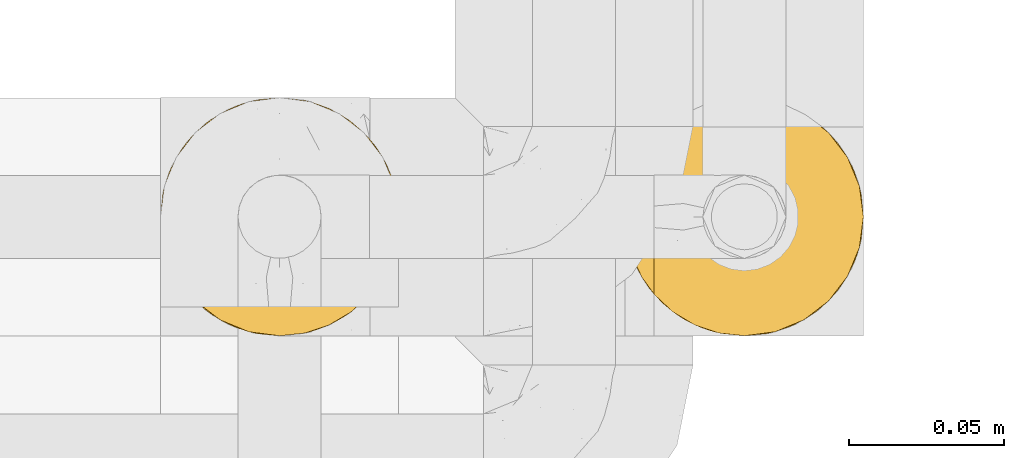
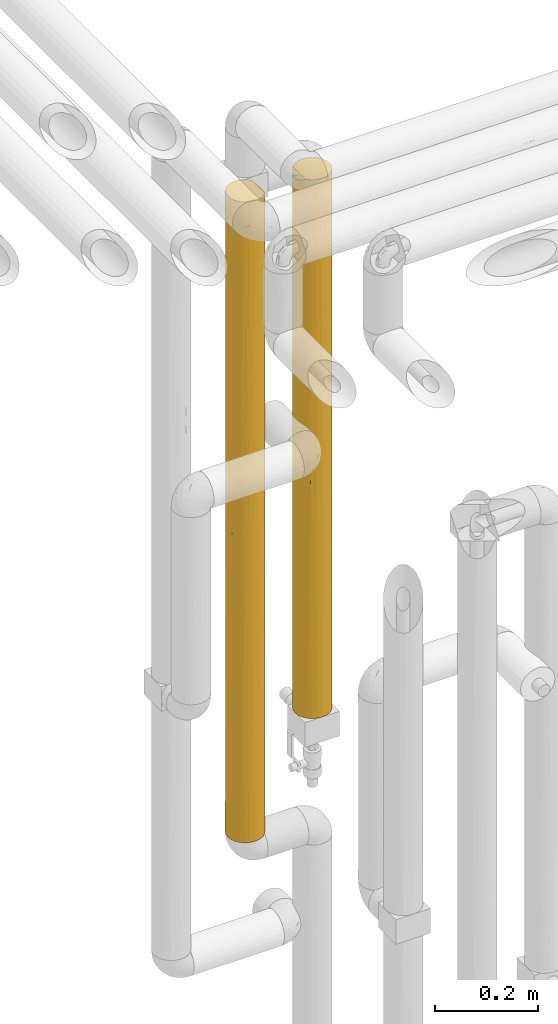
# One storey, part 40 of 824: 2 coverings.
"""IFC2X3 building model written with IfcOpenShell, lengths in millimetres."""

import ifcopenshell
import ifcopenshell.guid

model = None  # the IFC model being written
_history = None  # IfcOwnerHistory: only IFC2X3 demands one
_inside = {}  # id of a spatial element -> (the spatial element, [elements in it])
_under = {}  # id of a project, library or spatial element -> (it, [spatial elements below it])
_declared = {}  # id of a project -> (the project, [libraries it declares])
_typed = {}  # id of a type object -> (the type object, [elements of that type])
_made_of = {}  # id of a material, layer set ... -> (it, [elements and type objects made of it])


def new_model(schema):
    """Start an empty IFC model of exactly this schema.

    Asked for "IFC4X3", IfcOpenShell would pick the latest addendum, in which some entities
    have other attributes; the version numbers below select the first issue.
    IFC2X3 requires an IfcOwnerHistory on every rooted entity: one is made here for all.
    """
    global model, _history
    if schema == "IFC4X3":
        model = ifcopenshell.file(schema_version=(4, 3, 0, 0))
    else:
        model = ifcopenshell.file(schema=schema)
    _inside.clear()
    _under.clear()
    _declared.clear()
    _typed.clear()
    _made_of.clear()
    _history = None
    if model.schema == "IFC2X3":
        org = make("IfcOrganization", Name="unknown")
        user = make(
            "IfcPersonAndOrganization",
            ThePerson=make("IfcPerson", FamilyName="unknown"),
            TheOrganization=org,
        )
        app = make(
            "IfcApplication",
            ApplicationDeveloper=org,
            Version="unknown",
            ApplicationFullName="unknown",
            ApplicationIdentifier="unknown",
        )
        _history = make(
            "IfcOwnerHistory",
            OwningUser=user,
            OwningApplication=app,
            ChangeAction="ADDED",
            CreationDate=0,
        )
    return model


def make(cls, **values):
    """One entity of the class cls with the attributes given. An attribute that is None is left unset."""
    return model.create_entity(
        cls, **{name: value for name, value in values.items() if value is not None}
    )


def entity(cls, *values):
    """Any entity or typed value of the class cls, its attributes in the order of the schema. None: left unset."""
    e = model.create_entity(cls)
    for i, value in enumerate(values):
        if value is not None:
            e[i] = value
    return e


def rooted(cls, **values):
    """An entity with a GlobalId (a new one), such as an element, a storey or a relation."""
    return make(cls, GlobalId=ifcopenshell.guid.new(), OwnerHistory=_history, **values)


def si_unit(unit_type, name, prefix=None):
    """IfcSIUnit, for example si_unit("LENGTHUNIT", "METRE", prefix="MILLI")."""
    return make("IfcSIUnit", UnitType=unit_type, Prefix=prefix, Name=name)


def converted_unit(unit_type, name, factor, base, dimensions=None, offset=None):
    """IfcConversionBasedUnit, such as the inch: factor (a typed value) times the base unit."""
    return make(
        "IfcConversionBasedUnit"
        if offset is None
        else "IfcConversionBasedUnitWithOffset",
        ConversionOffset=offset,
        Dimensions=None
        if dimensions is None
        else entity("IfcDimensionalExponents", *dimensions),
        UnitType=unit_type,
        Name=name,
        ConversionFactor=make(
            "IfcMeasureWithUnit", ValueComponent=factor, UnitComponent=base
        ),
    )


def derived_unit(unit_type, elements):
    """IfcDerivedUnit: a product of units, each with its exponent."""
    return make(
        "IfcDerivedUnit",
        Elements=[
            make("IfcDerivedUnitElement", Unit=unit, Exponent=power)
            for unit, power in elements
        ],
        UnitType=unit_type,
    )


def assignment(units):
    """IfcUnitAssignment: the units of a project."""
    return None if units is None else make("IfcUnitAssignment", Units=units)


def point(xyz):
    """IfcCartesianPoint."""
    return None if xyz is None else make("IfcCartesianPoint", Coordinates=xyz)


def direction(xyz):
    """IfcDirection."""
    return None if xyz is None else make("IfcDirection", DirectionRatios=xyz)


def frame(location, z_axis=None, x_axis=None):
    """IfcAxis2Placement3D, a coordinate frame: its origin and axes. An axis left out is left unset."""
    return make(
        "IfcAxis2Placement3D",
        Location=point(location),
        Axis=direction(z_axis),
        RefDirection=direction(x_axis),
    )


def origin():
    """The frame at (0, 0, 0) with its axes left unset."""
    return frame((0.0, 0.0, 0.0))


def place(relative_to, where):
    """IfcLocalPlacement: puts the frame where relative to a parent placement (None: the world)."""
    return make(
        "IfcLocalPlacement", PlacementRelTo=relative_to, RelativePlacement=where
    )


def context(
    kind, dimensions, precision=None, world=None, true_north=None, identifier=None
):
    """IfcGeometricRepresentationContext, for example the 3D "Model" context."""
    return make(
        "IfcGeometricRepresentationContext",
        ContextIdentifier=identifier,
        ContextType=kind,
        CoordinateSpaceDimension=dimensions,
        Precision=precision,
        WorldCoordinateSystem=world,
        TrueNorth=true_north,
    )


def subcontext(parent, identifier, kind, view, scale=None):
    """IfcGeometricRepresentationSubContext, for example "Body" below "Model"."""
    return make(
        "IfcGeometricRepresentationSubContext",
        ContextIdentifier=identifier,
        ContextType=kind,
        ParentContext=parent,
        TargetScale=scale,
        TargetView=view,
    )


def project(units=None, contexts=None):
    """IfcProject with its units and contexts."""
    return rooted(
        "IfcProject",
        Name="project",
        RepresentationContexts=contexts,
        UnitsInContext=assignment(units),
    )


def spatial(cls, under=None, at=None, **own):
    """A site, building, storey or space (cls), placed at a placement, below another one or the project."""
    s = rooted(cls, ObjectPlacement=at, **own)
    if under is not None:
        _under.setdefault(under.id(), (under, []))[1].append(s)
    return s


def faces_of(points, faces, orient=None, outer=None):
    """IfcFace entities. A face is a list of loops; a loop is a list of indices into points, from 0.

    orient and outer hold one flag for each loop. By default every Orientation is true, the
    first loop of a face is its IfcFaceOuterBound and the others are IfcFaceBound.
    """
    made = []
    for i, loops in enumerate(faces):
        bounds = []
        for j, loop in enumerate(loops):
            is_outer = j == 0 if outer is None else outer[i][j]
            bounds.append(
                make(
                    "IfcFaceOuterBound" if is_outer else "IfcFaceBound",
                    Bound=make("IfcPolyLoop", Polygon=[points[k] for k in loop]),
                    Orientation=True if orient is None else orient[i][j],
                )
            )
        made.append(make("IfcFace", Bounds=bounds))
    return made


def faceted_brep(points, faces, orient=None, outer=None, voids=None):
    """IfcFacetedBrep: a solid bounded by flat faces; with voids (closed shells), ...WithVoids."""
    shared = [point(p) for p in points]
    hull = make("IfcClosedShell", CfsFaces=faces_of(shared, faces, orient, outer))
    if voids is None:
        return make("IfcFacetedBrep", Outer=hull)
    return make(
        "IfcFacetedBrepWithVoids",
        Outer=hull,
        Voids=[
            make(cls, CfsFaces=faces_of(shared, fs, o, b)) for cls, fs, o, b in voids
        ],
    )


def shape(context_of_items, identifier, shape_type, items):
    """IfcShapeRepresentation: the items that make up one representation, for example the "Body"."""
    return make(
        "IfcShapeRepresentation",
        ContextOfItems=context_of_items,
        RepresentationIdentifier=identifier,
        RepresentationType=shape_type,
        Items=items,
    )


def made_of(thing, what):
    """Note that an element or type object is made of a material, layer set ...; save() writes the relation."""
    if what is not None:
        _made_of.setdefault(what.id(), (what, []))[1].append(thing)
    return thing


def element(
    cls,
    number,
    at=None,
    inside=None,
    cuts=None,
    type_object=None,
    material=None,
    context=None,
    identifier="Body",
    shape_type=None,
    held_by="IfcProductDefinitionShape",
    body=None,
    shapes=None,
    **own,
):
    """One element of the class cls, such as IfcWall. Its Tag is "e" and its number.

    at: its placement. inside: the storey or other place that contains it. cuts: it is an
    opening in that element (IfcRelVoidsElement). A single representation is given by context,
    identifier, shape_type and body (its items); several are given by shapes. held_by: the class
    of the entity that holds the representations. save() writes the other relations.
    """
    e = rooted(cls, Tag="e%d" % number, ObjectPlacement=at, **own)
    if body is not None:
        shapes = [shape(context, identifier, shape_type, body)]
    if shapes is not None:
        e.Representation = make(held_by, Representations=shapes)
    if inside is not None:
        _inside.setdefault(inside.id(), (inside, []))[1].append(e)
    if cuts is not None:
        rooted(
            "IfcRelVoidsElement", RelatingBuildingElement=cuts, RelatedOpeningElement=e
        )
    if type_object is not None:
        _typed.setdefault(type_object.id(), (type_object, []))[1].append(e)
    return made_of(e, material)


def aggregate(whole, parts):
    """IfcRelAggregates: a whole, such as a stair, and the parts it consists of."""
    return rooted("IfcRelAggregates", RelatingObject=whole, RelatedObjects=parts)


def save(model, path):
    """Write the relations noted so far, then the file.

    IfcRelAggregates (storeys below a building ...), IfcRelContainedInSpatialStructure (elements
    in a storey), IfcRelDefinesByType, IfcRelAssociatesMaterial and IfcRelDeclares: one each for
    every whole, place, type object, material and project.
    """
    for whole, parts in _under.values():
        aggregate(whole, parts)
    for where, things in _inside.values():
        rooted(
            "IfcRelContainedInSpatialStructure",
            RelatedElements=things,
            RelatingStructure=where,
        )
    for kind, things in _typed.values():
        rooted("IfcRelDefinesByType", RelatedObjects=things, RelatingType=kind)
    for what, things in _made_of.values():
        rooted("IfcRelAssociatesMaterial", RelatedObjects=things, RelatingMaterial=what)
    for by, libraries in _declared.values():
        rooted("IfcRelDeclares", RelatingContext=by, RelatedDefinitions=libraries)
    model.write(path)


model = new_model("IFC2X3")

# Units and contexts
model_context = context("Model", 3, precision=0.01, world=origin(), true_north=direction((6.12303176911189e-17, 1.0)))
body_context = subcontext(model_context, "Body", "Model", "MODEL_VIEW")
ifc_project = project(units=[si_unit("LENGTHUNIT", "METRE", prefix="MILLI"), si_unit("AREAUNIT", "SQUARE_METRE"), si_unit("VOLUMEUNIT", "CUBIC_METRE"), converted_unit("PLANEANGLEUNIT", "DEGREE", entity("IfcRatioMeasure", 0.0174532925199433), si_unit("PLANEANGLEUNIT", "RADIAN"), dimensions=[0, 0, 0, 0, 0, 0, 0]), si_unit("MASSUNIT", "GRAM", prefix="KILO"), derived_unit("MASSDENSITYUNIT", [(si_unit("MASSUNIT", "GRAM", prefix="KILO"), 1), (si_unit("LENGTHUNIT", "METRE"), -3)]), derived_unit("MOMENTOFINERTIAUNIT", [(si_unit("LENGTHUNIT", "METRE"), 4)]), si_unit("TIMEUNIT", "SECOND"), si_unit("FREQUENCYUNIT", "HERTZ"), si_unit("THERMODYNAMICTEMPERATUREUNIT", "DEGREE_CELSIUS"), derived_unit("THERMALTRANSMITTANCEUNIT", [(si_unit("MASSUNIT", "GRAM", prefix="KILO"), 1), (si_unit("THERMODYNAMICTEMPERATUREUNIT", "KELVIN"), -1), (si_unit("TIMEUNIT", "SECOND"), -3)]), derived_unit("VOLUMETRICFLOWRATEUNIT", [(si_unit("LENGTHUNIT", "METRE"), 3), (si_unit("TIMEUNIT", "SECOND"), -1)]), derived_unit("MASSFLOWRATEUNIT", [(si_unit("MASSUNIT", "GRAM", prefix="KILO"), 1), (si_unit("TIMEUNIT", "SECOND"), -1)]), derived_unit("ROTATIONALFREQUENCYUNIT", [(si_unit("TIMEUNIT", "SECOND"), -1)]), si_unit("ELECTRICCURRENTUNIT", "AMPERE"), si_unit("ELECTRICVOLTAGEUNIT", "VOLT"), si_unit("POWERUNIT", "WATT"), si_unit("FORCEUNIT", "NEWTON", prefix="KILO"), si_unit("ILLUMINANCEUNIT", "LUX"), si_unit("LUMINOUSFLUXUNIT", "LUMEN"), si_unit("LUMINOUSINTENSITYUNIT", "CANDELA"), derived_unit("USERDEFINED", [(si_unit("MASSUNIT", "GRAM", prefix="KILO"), -1), (si_unit("LENGTHUNIT", "METRE"), -2), (si_unit("TIMEUNIT", "SECOND"), 3), (si_unit("LUMINOUSFLUXUNIT", "LUMEN"), 1)]), derived_unit("LINEARVELOCITYUNIT", [(si_unit("LENGTHUNIT", "METRE"), 1), (si_unit("TIMEUNIT", "SECOND"), -1)]), si_unit("PRESSUREUNIT", "PASCAL"), derived_unit("USERDEFINED", [(si_unit("LENGTHUNIT", "METRE"), -2), (si_unit("MASSUNIT", "GRAM", prefix="KILO"), 1), (si_unit("TIMEUNIT", "SECOND"), -2)]), derived_unit("LINEARFORCEUNIT", [(si_unit("MASSUNIT", "GRAM", prefix="KILO"), 1), (si_unit("LENGTHUNIT", "METRE"), 1), (si_unit("TIMEUNIT", "SECOND"), -2), (si_unit("LENGTHUNIT", "METRE"), -1)]), derived_unit("PLANARFORCEUNIT", [(si_unit("MASSUNIT", "GRAM", prefix="KILO"), 1), (si_unit("LENGTHUNIT", "METRE"), 1), (si_unit("TIMEUNIT", "SECOND"), -2), (si_unit("LENGTHUNIT", "METRE"), -2)])], contexts=[model_context])

# Site, building, storey
site_placement = place(None, origin())
site = spatial("IfcSite", under=ifc_project, at=site_placement, CompositionType="ELEMENT")
building_placement = place(site_placement, origin())
building = spatial("IfcBuilding", under=site, at=building_placement, CompositionType="ELEMENT")
storey_placement = place(building_placement, frame((0.0, 0.0, 28200.0)))
storey = spatial("IfcBuildingStorey", under=building, at=storey_placement, CompositionType="ELEMENT", Elevation=28200.0)

# Coverings
covering_1_placement = place(storey_placement, frame((34952.89, 15782.05, 1307.5)))
element("IfcCovering", 1, at=covering_1_placement, inside=storey, PredefinedType="INSULATION", context=body_context, shape_type="Brep", body=[
    faceted_brep([(6.74, 20.8, 1.6), (2.9, 30.06, 1.6), (1.6, 40.0, 1.6), (2.9, 49.93, 1.6), (6.74, 59.2, 1.6), (12.84, 67.15, 1.6), (20.8, 73.25, 1.6), (30.06, 77.09, 1.6), (40.0, 78.4, 1.6), (48.2, 77.51, 1.6), (56.01, 74.9, 1.6), (63.08, 70.68, 1.6), (69.1, 65.05, 1.6), (69.1, 14.94, 1.6), (63.08, 9.31, 1.6), (56.01, 5.09, 1.6), (48.2, 2.48, 1.6), (40.0, 1.6, 1.6), (30.06, 2.9, 1.6), (20.8, 6.74, 1.6), (12.84, 12.84, 1.6), (1.6, 40.0, 1513.5), (2.9, 30.06, 1513.5), (6.74, 20.8, 1513.5), (12.84, 12.84, 1513.5), (20.8, 6.74, 1513.5), (30.06, 2.9, 1513.5), (40.0, 1.6, 1513.5), (48.16, 2.47, 1513.5), (55.94, 5.06, 1513.5), (62.99, 9.24, 1513.5), (69.0, 14.82, 1513.5), (69.0, 65.17, 1513.5), (62.99, 70.75, 1513.5), (55.94, 74.93, 1513.5), (48.16, 77.52, 1513.5), (40.0, 78.4, 1513.5), (30.06, 77.09, 1513.5), (20.8, 73.25, 1513.5), (12.84, 67.15, 1513.5), (6.74, 59.2, 1513.5), (2.9, 49.93, 1513.5), (9.53, 63.37, 1254.3), (8.19, 61.51, 485.12), (17.02, 70.76, 616.68), (16.62, 70.46, 297.59), (16.62, 70.46, 1189.22), (2.34, 47.54, 1188.94), (4.37, 54.34, 1314.28), (4.52, 54.69, 1074.52), (25.3, 75.47, 204.96), (31.9, 77.53, 329.8), (2.32, 47.41, 921.21), (1.6, 40.0, 1080.75), (4.9, 55.59, 800.5), (1.6, 40.0, 324.8), (2.43, 47.94, 288.89), (40.0, 78.4, 324.8), (31.64, 77.48, 539.4), (33.12, 77.77, 951.85), (28.03, 76.48, 719.21), (25.3, 75.47, 983.78), (25.3, 75.47, 1268.44), (32.71, 77.7, 1188.94), (9.53, 63.37, 255.92), (4.52, 54.69, 175.66), (2.55, 48.52, 674.17), (25.3, 75.47, 454.64), (4.52, 54.69, 402.11), (17.9, 71.4, 946.7), (11.57, 65.81, 984.31), (40.0, 78.4, 1297.12), (1.6, 40.0, 1297.12), (1.6, 40.0, 648.0), (1.6, 40.0, 864.38), (9.53, 63.37, 714.31), (40.0, 78.4, 1080.75), (40.0, 78.4, 864.38), (40.0, 78.4, 648.0), (4.52, 54.69, 602.29), (40.0, 78.4, 217.97), (40.0, 78.4, 434.34), (48.41, 77.46, 864.38), (55.63, 75.07, 815.72), (49.96, 77.08, 541.17), (52.17, 76.41, 262.4), (59.58, 73.03, 1000.69), (52.12, 76.43, 1216.13), (59.58, 73.03, 1294.15), (59.71, 72.95, 245.23), (77.78, 46.82, 1504.71), (78.4, 40.0, 1287.72), (77.0, 50.24, 1261.84), (78.4, 40.0, 443.64), (78.4, 40.0, 227.27), (77.5, 48.24, 335.45), (76.0, 53.36, 8.5), (74.58, 56.68, 384.99), (74.53, 56.78, 1092.98), (73.77, 58.26, 1300.86), (75.97, 53.43, 1506.52), (66.14, 68.12, 1216.12), (67.04, 67.25, 938.77), (77.79, 46.78, 10.29), (70.57, 63.23, 410.64), (71.13, 62.48, 196.11), (66.24, 68.03, 287.24), (66.5, 67.78, 548.36), (78.4, 40.0, 1071.35), (77.38, 48.77, 973.87), (59.66, 72.98, 485.18), (78.4, 40.0, 876.39), (76.88, 50.68, 653.07), (78.4, 40.0, 660.02), (70.87, 62.83, 1155.43), (71.79, 61.52, 947.04), (73.07, 59.51, 5.57), (62.05, 71.43, 743.38), (75.0, 55.77, 846.38), (78.4, 40.0, 10.9), (73.01, 59.61, 1509.48), (74.34, 57.17, 650.34), (70.91, 62.77, 717.19), (78.4, 40.0, 1504.1), (52.17, 3.58, 262.4), (59.66, 7.01, 485.18), (49.96, 2.91, 541.17), (73.77, 21.73, 1300.86), (77.0, 29.75, 1261.84), (75.97, 26.56, 1506.52), (71.13, 17.51, 196.11), (74.58, 23.31, 384.99), (70.57, 16.76, 410.64), (40.0, 1.6, 434.34), (70.91, 17.22, 717.19), (62.05, 8.56, 743.38), (66.5, 12.21, 548.36), (52.12, 3.56, 1216.13), (59.58, 6.96, 1238.43), (70.87, 17.16, 1155.43), (66.14, 11.87, 1216.12), (77.78, 33.17, 1504.71), (67.04, 12.74, 938.77), (71.79, 18.47, 947.04), (76.0, 26.63, 8.5), (77.5, 31.75, 335.45), (77.79, 33.21, 10.29), (77.38, 31.23, 973.87), (55.63, 4.92, 815.72), (73.01, 20.38, 1509.48), (40.0, 1.6, 1297.12), (40.0, 1.6, 1190.29), (40.0, 1.6, 1080.75), (76.88, 29.31, 653.07), (59.58, 6.96, 1000.69), (59.75, 7.07, 217.41), (66.24, 11.96, 287.24), (48.41, 2.53, 864.38), (40.0, 1.6, 648.0), (40.0, 1.6, 867.09), (40.0, 1.6, 864.38), (40.0, 1.6, 650.71), (40.0, 1.6, 217.97), (75.0, 24.22, 846.38), (74.34, 22.82, 650.34), (74.53, 23.21, 1092.98), (73.07, 20.48, 5.57), (16.62, 9.53, 1254.3), (9.53, 16.62, 1189.22), (25.3, 4.52, 406.92), (32.71, 2.29, 326.15), (32.07, 2.42, 623.25), (25.3, 4.52, 1079.45), (22.93, 5.59, 1282.78), (28.78, 3.27, 853.31), (33.21, 2.2, 1053.48), (21.48, 6.35, 883.7), (23.82, 5.17, 655.64), (2.46, 31.9, 329.8), (2.52, 31.64, 539.4), (16.62, 9.53, 255.92), (9.53, 16.62, 297.59), (8.59, 17.9, 946.93), (14.15, 11.59, 989.78), (4.52, 25.3, 1268.44), (2.29, 32.71, 1188.94), (4.52, 25.3, 983.78), (18.36, 8.27, 490.59), (9.25, 16.99, 618.61), (2.22, 33.12, 951.85), (3.51, 28.03, 719.21), (4.52, 25.3, 204.96), (26.92, 3.89, 196.25), (4.52, 25.3, 454.64), (29.95, 2.93, 1273.39), (16.62, 9.53, 725.25)], [[[0, 1, 2, 3, 4, 5, 6, 7, 8, 9, 10, 11, 12, 13, 14, 15, 16, 17, 18, 19, 20]], [[21, 22, 23, 24, 25, 26, 27, 28, 29, 30, 31, 32, 33, 34, 35, 36, 37, 38, 39, 40, 41]], [[39, 42, 40]], [[43, 44, 45]], [[42, 39, 46]], [[47, 48, 49]], [[7, 50, 51]], [[52, 53, 47]], [[49, 54, 52]], [[2, 55, 56]], [[57, 51, 58]], [[59, 60, 61]], [[38, 37, 62]], [[6, 5, 45]], [[62, 63, 61]], [[62, 46, 38]], [[38, 46, 39]], [[7, 6, 50]], [[45, 5, 64]], [[4, 3, 65]], [[52, 54, 66]], [[67, 45, 44]], [[45, 67, 50]], [[56, 68, 65]], [[46, 69, 70]], [[37, 36, 71]], [[61, 63, 59]], [[72, 41, 47]], [[70, 49, 42]], [[5, 4, 64]], [[7, 51, 8]], [[64, 43, 45]], [[70, 42, 46]], [[47, 49, 52]], [[66, 55, 73, 74]], [[48, 42, 49]], [[65, 64, 4]], [[43, 64, 68]], [[71, 63, 37]], [[46, 62, 61]], [[75, 70, 69]], [[44, 69, 60]], [[46, 61, 69]], [[70, 75, 54]], [[63, 71, 76]], [[63, 76, 59]], [[37, 63, 62]], [[60, 77, 78]], [[51, 67, 58]], [[59, 77, 60]], [[44, 60, 67]], [[59, 76, 77]], [[47, 53, 72]], [[72, 21, 41]], [[48, 47, 41]], [[70, 54, 49]], [[66, 74, 52]], [[79, 75, 43]], [[75, 79, 54]], [[41, 40, 48]], [[42, 48, 40]], [[54, 79, 66]], [[66, 68, 56]], [[45, 50, 6]], [[51, 50, 67]], [[67, 60, 58]], [[51, 57, 80, 8]], [[60, 78, 58]], [[58, 78, 81, 57]], [[60, 69, 61]], [[75, 69, 44]], [[74, 53, 52]], [[68, 66, 79]], [[3, 2, 56]], [[64, 65, 68]], [[3, 56, 65]], [[66, 56, 55]], [[79, 43, 68]], [[44, 43, 75]], [[82, 83, 84]], [[9, 80, 85]], [[86, 87, 88]], [[88, 34, 33]], [[82, 84, 78]], [[85, 89, 10]], [[90, 91, 92]], [[93, 94, 95]], [[87, 35, 34]], [[95, 96, 97]], [[98, 99, 92]], [[100, 90, 92]], [[33, 32, 101]], [[87, 71, 35]], [[82, 78, 77, 76]], [[84, 85, 81]], [[86, 101, 102]], [[88, 33, 101]], [[103, 96, 95]], [[104, 105, 106]], [[107, 104, 106]], [[92, 108, 109]], [[84, 81, 78]], [[89, 85, 110]], [[111, 109, 108]], [[106, 12, 11]], [[112, 111, 113, 93]], [[114, 98, 115]], [[96, 116, 105]], [[102, 117, 86]], [[109, 118, 98]], [[100, 92, 99]], [[94, 119, 103]], [[9, 85, 10]], [[89, 110, 106]], [[95, 112, 93]], [[109, 112, 118]], [[32, 120, 99]], [[98, 118, 115]], [[82, 87, 86]], [[35, 71, 36]], [[111, 112, 109]], [[109, 98, 92]], [[107, 110, 117]], [[105, 116, 12]], [[103, 95, 94]], [[112, 95, 97]], [[118, 121, 122]], [[80, 9, 8]], [[106, 11, 89]], [[110, 85, 84]], [[87, 82, 76]], [[83, 86, 117]], [[121, 118, 112]], [[76, 71, 87]], [[115, 122, 102]], [[114, 115, 102]], [[122, 107, 117]], [[122, 117, 102]], [[110, 84, 83]], [[122, 121, 104]], [[106, 110, 107]], [[122, 115, 118]], [[114, 102, 101]], [[32, 114, 101]], [[99, 98, 114]], [[32, 99, 114]], [[99, 120, 100]], [[122, 104, 107]], [[97, 96, 105]], [[106, 105, 12]], [[97, 105, 104]], [[83, 117, 110]], [[82, 86, 83]], [[112, 97, 121]], [[104, 121, 97]], [[86, 88, 101]], [[34, 88, 87]], [[91, 90, 123]], [[91, 108, 92]], [[85, 80, 57, 81]], [[10, 89, 11]], [[124, 125, 126]], [[127, 128, 129]], [[130, 131, 132]], [[124, 126, 133]], [[134, 135, 136]], [[137, 138, 29]], [[139, 31, 140]], [[141, 129, 128]], [[142, 143, 139]], [[130, 144, 131]], [[94, 145, 146]], [[140, 31, 30]], [[111, 108, 147]], [[128, 91, 141]], [[145, 94, 93]], [[126, 125, 148]], [[149, 127, 129]], [[137, 150, 151, 152]], [[131, 145, 153]], [[111, 147, 153]], [[140, 138, 154]], [[16, 15, 124]], [[125, 124, 155]], [[138, 137, 154]], [[14, 13, 156]], [[157, 158, 126]], [[157, 152, 159, 160, 161, 158]], [[135, 134, 142]], [[155, 14, 156]], [[16, 124, 162]], [[144, 146, 145]], [[141, 91, 123]], [[158, 133, 126]], [[29, 28, 137]], [[153, 147, 163]], [[163, 164, 153]], [[142, 140, 154]], [[142, 139, 140]], [[137, 28, 150]], [[157, 137, 152]], [[165, 147, 128]], [[108, 128, 147]], [[130, 13, 166]], [[132, 134, 136]], [[146, 119, 94]], [[14, 155, 15]], [[17, 16, 162]], [[153, 145, 93]], [[145, 131, 144]], [[113, 111, 153, 93]], [[147, 165, 163]], [[148, 125, 135]], [[137, 157, 154]], [[28, 27, 150]], [[143, 163, 165]], [[164, 163, 134]], [[135, 142, 154]], [[134, 163, 143]], [[148, 135, 154]], [[135, 125, 136]], [[125, 156, 136]], [[132, 136, 156]], [[143, 165, 139]], [[134, 143, 142]], [[165, 127, 139]], [[139, 127, 31]], [[128, 127, 165]], [[31, 127, 149]], [[156, 13, 130]], [[132, 131, 164]], [[130, 166, 144]], [[156, 130, 132]], [[154, 157, 148]], [[126, 148, 157]], [[132, 164, 134]], [[131, 153, 164]], [[140, 30, 138]], [[29, 138, 30]], [[128, 108, 91]], [[125, 155, 156]], [[15, 155, 124]], [[124, 133, 162]], [[167, 24, 168]], [[169, 170, 171]], [[18, 162, 170]], [[25, 24, 167]], [[167, 172, 173]], [[174, 175, 172]], [[22, 21, 72]], [[174, 176, 177]], [[171, 177, 169]], [[55, 178, 179]], [[180, 181, 20]], [[168, 182, 183]], [[184, 185, 186]], [[181, 187, 188]], [[189, 190, 186]], [[1, 0, 191]], [[192, 18, 170]], [[23, 22, 184]], [[23, 168, 24]], [[193, 181, 188]], [[181, 193, 191]], [[168, 184, 186]], [[1, 191, 178]], [[0, 20, 181]], [[133, 170, 162]], [[194, 172, 175]], [[184, 168, 23]], [[186, 185, 189]], [[183, 172, 167]], [[20, 19, 180]], [[1, 178, 2]], [[180, 187, 181]], [[183, 167, 168]], [[26, 194, 27]], [[173, 172, 194]], [[192, 180, 19]], [[187, 180, 169]], [[72, 185, 22]], [[195, 183, 182]], [[188, 182, 190]], [[168, 186, 182]], [[183, 195, 176]], [[185, 72, 53]], [[185, 53, 189]], [[22, 185, 184]], [[190, 74, 73]], [[178, 193, 179]], [[189, 74, 190]], [[188, 190, 193]], [[189, 53, 74]], [[18, 17, 162]], [[171, 170, 133]], [[170, 169, 192]], [[171, 133, 158, 161, 160, 159]], [[174, 172, 176]], [[180, 192, 169]], [[19, 18, 192]], [[190, 182, 186]], [[195, 182, 188]], [[181, 191, 0]], [[178, 191, 193]], [[193, 190, 179]], [[178, 55, 2]], [[190, 73, 179]], [[55, 179, 73]], [[177, 171, 174]], [[187, 177, 195]], [[171, 159, 174]], [[175, 159, 152, 151]], [[159, 175, 174]], [[194, 151, 150, 27]], [[151, 194, 175]], [[173, 26, 25]], [[183, 176, 172]], [[177, 176, 195]], [[26, 173, 194]], [[25, 167, 173]], [[177, 187, 169]], [[188, 187, 195]], [[12, 116, 96, 103, 119, 146, 144, 166, 13]], [[31, 149, 129, 141, 123, 90, 100, 120, 32]]]),
])
covering_2_placement = place(storey_placement, frame((35102.89, 15782.05, 1549.85)))
element("IfcCovering", 2, at=covering_2_placement, inside=storey, PredefinedType="INSULATION", context=body_context, shape_type="Brep", body=[
    faceted_brep([(73.25, 20.8, 1271.05), (77.09, 30.06, 1271.05), (78.4, 40.0, 1271.05), (77.09, 49.93, 1271.05), (73.25, 59.2, 1271.05), (67.15, 67.15, 1271.05), (59.2, 73.25, 1271.05), (49.93, 77.09, 1271.05), (40.0, 78.4, 1271.05), (31.79, 77.51, 1271.05), (23.98, 74.9, 1271.05), (16.91, 70.68, 1271.05), (10.9, 65.05, 1271.05), (10.9, 14.94, 1271.05), (16.91, 9.31, 1271.05), (23.98, 5.09, 1271.05), (31.79, 2.48, 1271.05), (40.0, 1.6, 1271.05), (49.93, 2.9, 1271.05), (59.2, 6.74, 1271.05), (67.15, 12.84, 1271.05), (73.25, 20.8, 0.0), (67.15, 12.84, 0.0), (59.2, 6.74, 0.0), (49.93, 2.9, 0.0), (40.0, 1.6, 0.0), (30.06, 2.9, 0.0), (20.8, 6.74, 0.0), (12.84, 12.84, 0.0), (6.74, 20.8, 0.0), (2.9, 30.06, 0.0), (1.6, 40.0, 0.0), (2.9, 49.93, 0.0), (6.74, 59.2, 0.0), (12.84, 67.15, 0.0), (20.8, 73.25, 0.0), (30.06, 77.09, 0.0), (40.0, 78.4, 0.0), (49.93, 77.09, 0.0), (59.2, 73.25, 0.0), (67.15, 67.15, 0.0), (73.25, 59.2, 0.0), (77.09, 49.93, 0.0), (78.4, 40.0, 0.0), (77.09, 30.06, 0.0), (70.46, 63.37, 259.19), (70.46, 63.37, 635.53), (63.37, 70.46, 903.77), (70.46, 63.37, 1001.72), (63.37, 70.46, 324.27), (78.4, 40.0, 432.75), (77.73, 47.1, 324.56), (77.47, 48.35, 644.74), (77.7, 47.26, 960.09), (78.4, 40.0, 1054.68), (78.4, 40.0, 865.49), (54.69, 75.47, 245.05), (75.47, 54.69, 367.29), (78.4, 40.0, 1068.27), (78.4, 40.0, 216.37), (47.31, 77.69, 950.11), (40.0, 78.4, 1068.27), (47.28, 77.7, 324.56), (54.69, 75.47, 529.72), (54.69, 75.47, 1001.72), (75.47, 54.69, 903.77), (46.88, 77.77, 561.65), (51.83, 76.52, 765.72), (63.03, 70.72, 614.02), (74.8, 56.22, 605.69), (40.0, 78.4, 216.37), (78.4, 40.0, 649.12), (40.0, 78.4, 405.56), (40.0, 78.4, 432.75), (40.0, 78.4, 649.12), (40.0, 78.4, 838.31), (40.0, 78.4, 865.49), (40.0, 78.4, 621.93), (40.0, 78.4, 1054.68), (27.82, 76.41, 994.44), (18.19, 71.6, 547.54), (14.07, 68.32, 731.38), (20.33, 72.98, 809.75), (20.33, 72.98, 1055.19), (13.75, 68.03, 994.43), (1.6, 40.0, 216.37), (2.29, 47.27, 306.32), (2.5, 48.3, 614.38), (1.6, 40.0, 396.26), (1.6, 40.0, 612.63), (1.6, 40.0, 829.0), (25.3, 75.47, 407.79), (26.35, 75.89, 189.76), (16.62, 70.46, 281.08), (32.49, 77.65, 310.97), (29.34, 76.89, 689.95), (2.47, 48.15, 937.19), (4.0, 53.36, 1264.15), (6.92, 59.51, 1267.08), (5.4, 56.66, 923.75), (9.4, 63.2, 861.72), (9.05, 62.73, 632.57), (4.99, 55.78, 686.7), (4.52, 54.69, 355.87), (2.2, 46.78, 1262.36), (1.6, 40.0, 1045.38), (1.6, 40.0, 1261.75), (8.87, 62.48, 1076.47), (9.53, 63.37, 252.51), (16.62, 9.53, 281.08), (9.53, 16.62, 252.51), (18.19, 8.39, 547.54), (14.07, 11.67, 731.38), (9.05, 17.26, 632.57), (2.29, 32.72, 306.32), (6.92, 20.48, 1267.08), (8.7, 17.74, 1057.17), (5.4, 23.33, 923.75), (4.52, 25.3, 355.87), (2.47, 31.84, 937.19), (2.5, 31.69, 614.38), (26.35, 4.1, 189.76), (8.9, 17.46, 844.93), (4.0, 26.63, 1264.15), (32.49, 2.34, 310.97), (40.0, 1.6, 621.93), (29.34, 3.1, 689.95), (25.3, 4.52, 407.79), (40.0, 1.6, 216.37), (40.0, 1.6, 405.56), (2.2, 33.21, 1262.36), (13.75, 11.96, 994.43), (27.82, 3.58, 994.44), (40.0, 1.6, 1054.68), (20.33, 7.01, 1056.08), (20.33, 7.01, 809.75), (5.04, 24.09, 585.95), (40.0, 1.6, 838.31), (63.37, 9.53, 259.19), (70.46, 16.62, 324.27), (47.1, 2.26, 946.49), (48.35, 2.52, 626.31), (54.69, 4.52, 903.77), (54.69, 4.52, 367.29), (47.26, 2.29, 310.97), (56.26, 5.21, 604.43), (77.69, 32.68, 950.11), (75.47, 25.3, 245.05), (70.72, 16.96, 614.02), (75.47, 25.3, 529.72), (77.7, 32.71, 324.56), (70.46, 16.62, 903.77), (75.47, 25.3, 1001.72), (63.37, 9.53, 1001.72), (63.37, 9.53, 635.53), (77.77, 33.12, 561.65), (76.52, 28.16, 765.72)], [[[0, 1, 2, 3, 4, 5, 6, 7, 8, 9, 10, 11, 12, 13, 14, 15, 16, 17, 18, 19, 20]], [[21, 22, 23, 24, 25, 26, 27, 28, 29, 30, 31, 32, 33, 34, 35, 36, 37, 38, 39, 40, 41, 42, 43, 44]], [[41, 40, 45]], [[46, 47, 48]], [[46, 45, 49]], [[50, 51, 52]], [[53, 54, 55]], [[56, 49, 39]], [[57, 42, 41]], [[51, 42, 57]], [[3, 2, 58, 54]], [[59, 43, 42]], [[60, 61, 7]], [[45, 40, 49]], [[39, 38, 56]], [[39, 49, 40]], [[56, 62, 63]], [[7, 6, 64]], [[42, 51, 59]], [[47, 64, 6]], [[4, 65, 48]], [[3, 65, 4]], [[66, 67, 63]], [[4, 48, 5]], [[47, 6, 5]], [[68, 46, 49]], [[69, 65, 52]], [[38, 37, 70]], [[61, 8, 7]], [[68, 49, 63]], [[52, 55, 71, 50]], [[63, 62, 66]], [[45, 46, 57]], [[46, 48, 65]], [[47, 5, 48]], [[47, 68, 67]], [[60, 64, 67]], [[57, 41, 45]], [[70, 62, 38]], [[49, 56, 63]], [[62, 70, 72, 73]], [[62, 73, 66]], [[38, 62, 56]], [[67, 74, 75, 76]], [[76, 60, 67]], [[66, 74, 67]], [[47, 67, 64]], [[66, 73, 77, 74]], [[7, 64, 60]], [[60, 76, 78, 61]], [[59, 51, 50]], [[57, 69, 52]], [[57, 52, 51]], [[52, 53, 55]], [[53, 52, 65]], [[54, 53, 3]], [[3, 53, 65]], [[67, 68, 63]], [[46, 68, 47]], [[57, 46, 69]], [[65, 69, 46]], [[9, 78, 79]], [[80, 81, 82]], [[83, 82, 84]], [[32, 85, 86]], [[87, 88, 89, 90]], [[91, 92, 93]], [[93, 80, 91]], [[94, 91, 95]], [[87, 90, 96]], [[94, 92, 91]], [[97, 98, 99]], [[11, 84, 12]], [[83, 79, 82]], [[100, 101, 102]], [[79, 83, 10]], [[82, 79, 95]], [[103, 87, 102]], [[104, 96, 105]], [[105, 106, 104]], [[35, 34, 93]], [[86, 85, 88]], [[32, 103, 33]], [[100, 107, 84]], [[104, 97, 96]], [[107, 98, 12]], [[93, 34, 108]], [[95, 77, 94]], [[108, 101, 93]], [[36, 70, 37]], [[79, 10, 9]], [[103, 102, 101]], [[95, 91, 80]], [[96, 97, 99]], [[90, 105, 96]], [[100, 102, 99]], [[102, 96, 99]], [[87, 86, 88]], [[34, 33, 108]], [[80, 82, 95]], [[79, 75, 95]], [[94, 77, 73, 72, 70]], [[33, 103, 108]], [[101, 108, 103]], [[93, 101, 80]], [[81, 80, 101]], [[100, 81, 101]], [[84, 82, 81]], [[70, 36, 94]], [[92, 94, 36]], [[36, 35, 92]], [[93, 92, 35]], [[32, 31, 85]], [[87, 103, 86]], [[32, 86, 103]], [[84, 11, 83]], [[10, 83, 11]], [[107, 99, 98]], [[81, 100, 84]], [[84, 107, 12]], [[99, 107, 100]], [[9, 8, 61, 78]], [[79, 78, 76, 75]], [[96, 102, 87]], [[95, 75, 74, 77]], [[28, 109, 110]], [[111, 112, 113]], [[114, 88, 85]], [[30, 85, 31]], [[13, 115, 116]], [[115, 117, 116]], [[29, 118, 30]], [[117, 119, 120]], [[121, 109, 27]], [[119, 105, 90]], [[29, 28, 110]], [[116, 117, 122]], [[123, 117, 115]], [[124, 121, 26]], [[124, 125, 126]], [[127, 111, 109]], [[114, 120, 88]], [[124, 128, 129, 125]], [[105, 119, 130]], [[13, 131, 14]], [[27, 109, 28]], [[15, 132, 16]], [[133, 16, 132]], [[134, 14, 131]], [[134, 15, 14]], [[123, 130, 119]], [[134, 135, 132]], [[136, 117, 120]], [[126, 132, 135]], [[135, 111, 126]], [[133, 17, 16]], [[130, 106, 105]], [[120, 119, 90]], [[119, 117, 123]], [[120, 90, 89, 88]], [[120, 118, 136]], [[127, 126, 111]], [[110, 113, 118]], [[126, 127, 124]], [[137, 132, 126]], [[113, 110, 109]], [[118, 29, 110]], [[112, 111, 135]], [[113, 109, 111]], [[135, 131, 112]], [[122, 131, 116]], [[26, 25, 128]], [[121, 124, 127]], [[26, 128, 124]], [[109, 121, 127]], [[27, 26, 121]], [[114, 30, 118]], [[30, 114, 85]], [[120, 114, 118]], [[135, 134, 131]], [[15, 134, 132]], [[117, 136, 122]], [[13, 116, 131]], [[113, 112, 122]], [[131, 122, 112]], [[132, 137, 133]], [[118, 113, 136]], [[136, 113, 122]], [[125, 137, 126]], [[138, 22, 139]], [[140, 141, 142]], [[18, 133, 140]], [[18, 142, 19]], [[24, 23, 143]], [[144, 129, 128]], [[44, 43, 59]], [[58, 2, 1]], [[144, 141, 129]], [[142, 141, 145]], [[146, 58, 1]], [[21, 147, 139]], [[148, 139, 149]], [[147, 150, 149]], [[24, 128, 25]], [[18, 17, 133]], [[137, 140, 133]], [[151, 152, 0]], [[153, 20, 19]], [[21, 44, 147]], [[21, 139, 22]], [[142, 153, 19]], [[151, 0, 20]], [[1, 0, 152]], [[151, 153, 154]], [[154, 138, 139]], [[148, 154, 139]], [[155, 156, 149]], [[22, 138, 23]], [[149, 150, 155]], [[138, 154, 143]], [[151, 148, 156]], [[146, 152, 156]], [[154, 153, 142]], [[151, 20, 153]], [[143, 23, 138]], [[59, 150, 44]], [[139, 147, 149]], [[150, 59, 50]], [[150, 50, 155]], [[44, 150, 147]], [[156, 71, 55]], [[55, 146, 156]], [[155, 71, 156]], [[151, 156, 152]], [[155, 50, 71]], [[1, 152, 146]], [[146, 55, 54, 58]], [[141, 140, 137]], [[18, 140, 142]], [[141, 137, 125, 129]], [[141, 143, 145]], [[144, 24, 143]], [[24, 144, 128]], [[141, 144, 143]], [[156, 148, 149]], [[154, 148, 151]], [[143, 154, 145]], [[142, 145, 154]], [[104, 106, 130, 123, 115, 13, 12, 98, 97]]]),
])

save(model, "model.ifc")
